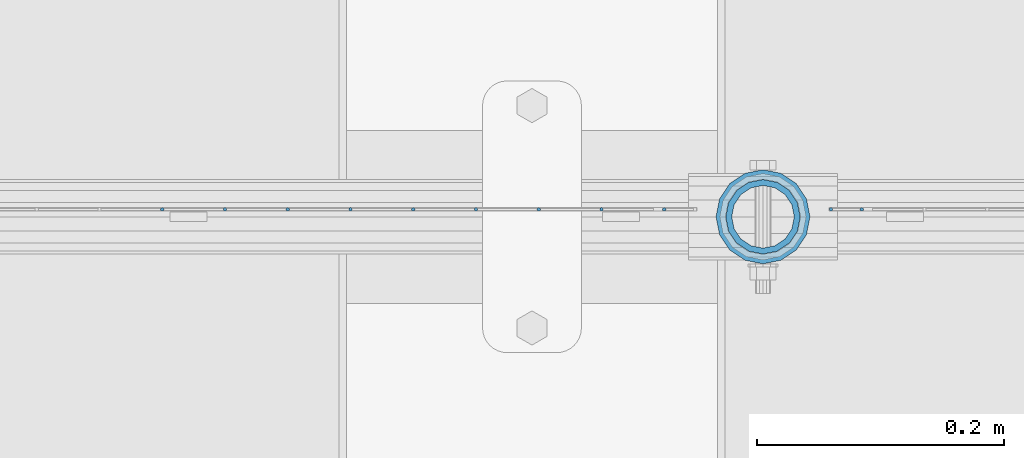
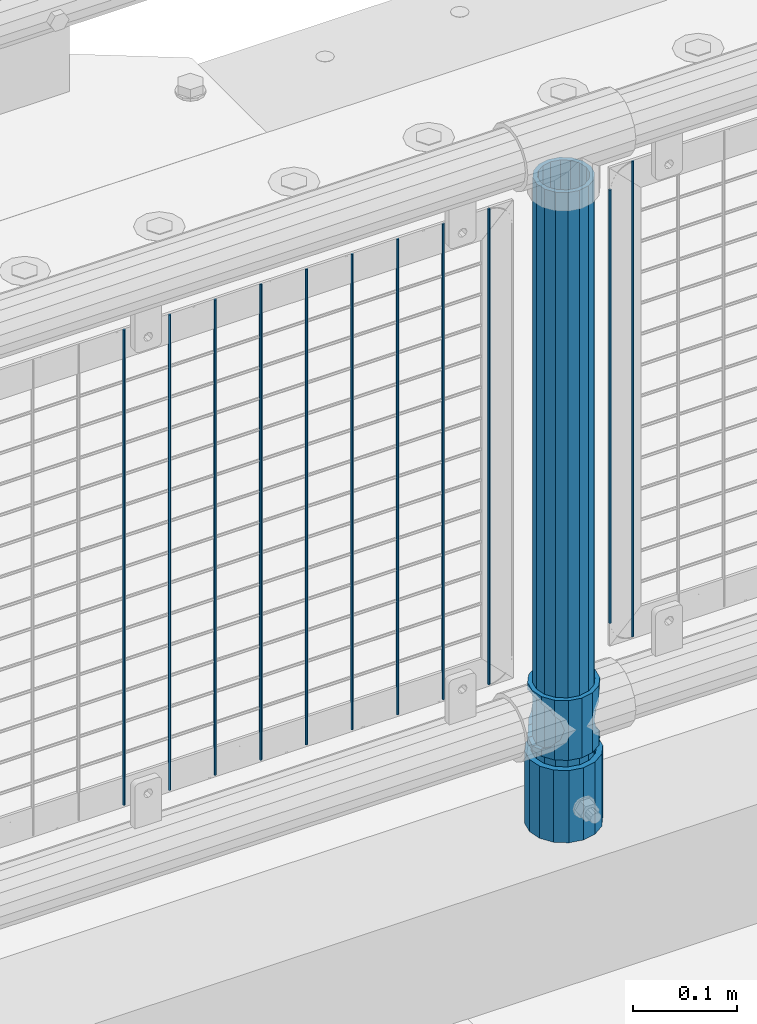
# One storey, part 73 of 270: 14 columns.
"""IFC2X3 building model written with IfcOpenShell, lengths in millimetres."""

from ifc_helpers import new_model, si_unit, frame, origin_with_axes, place, context, subcontext, project, spatial, faceted_brep, material, type_object, element, save


model = new_model("IFC2X3")

# Units and contexts
model_context = context("Model", 3, precision=1e-05, world=origin_with_axes())
body_context = subcontext(model_context, "Body", "Model", "MODEL_VIEW")
ifc_project = project(units=[si_unit("LENGTHUNIT", "METRE", prefix="MILLI"), si_unit("AREAUNIT", "SQUARE_METRE"), si_unit("VOLUMEUNIT", "CUBIC_METRE"), si_unit("MASSUNIT", "GRAM", prefix="KILO"), si_unit("TIMEUNIT", "SECOND"), si_unit("PLANEANGLEUNIT", "RADIAN"), si_unit("SOLIDANGLEUNIT", "STERADIAN"), si_unit("THERMODYNAMICTEMPERATUREUNIT", "DEGREE_CELSIUS"), si_unit("LUMINOUSINTENSITYUNIT", "LUMEN")], contexts=[model_context])

# Site, building, storey
site_placement = place(None, origin_with_axes())
site = spatial("IfcSite", under=ifc_project, at=site_placement, CompositionType="ELEMENT")
building_placement = place(site_placement, origin_with_axes())
building = spatial("IfcBuilding", under=site, at=building_placement, Name="Standard", CompositionType="ELEMENT")
storey_placement = place(building_placement, origin_with_axes())
storey = spatial("IfcBuildingStorey", under=building, at=storey_placement, Name="Undefined", CompositionType="ELEMENT", Elevation=0.0)

# Columns
ifc_material_1 = material()
column_type_1 = type_object("IfcColumnType", PredefinedType="NOTDEFINED")
column_1_placement = place(storey_placement, frame((3887.0, -16335.5, 168.02), z_axis=(-1.0, 0.0, 0.0), x_axis=(0.0, 0.0, 1.0)))
element("IfcColumn", 1, at=column_1_placement, inside=storey, type_object=column_type_1, material=ifc_material_1, context=body_context, shape_type="Brep", body=[
    faceted_brep([(0.0, -25.3500000000004, 0.0), (0.0, -23.4203461491616, 9.70102501045403), (760.0, -23.4203461491616, 9.70102501045403), (760.0, -25.3500000000004, 0.0), (0.0, -17.9251569030785, 17.9251569030785), (760.0, -17.9251569030785, 17.9251569030785), (0.0, -9.70102501045585, 23.4203461491597), (760.0, -9.70102501045585, 23.4203461491597), (0.0, 0.0, 25.3499999999985), (760.0, 0.0, 25.3499999999985), (0.0, 9.70102501045585, 23.4203461491597), (760.0, 9.70102501045585, 23.4203461491597), (0.0, 17.9251569030785, 17.9251569030785), (760.0, 17.9251569030785, 17.9251569030785), (0.0, 23.4203461491616, 9.70102501045403), (760.0, 23.4203461491616, 9.70102501045403), (0.0, 25.3500000000004, 0.0), (760.0, 25.3500000000004, 0.0), (0.0, 23.4203461491616, -9.70102501045403), (760.0, 23.4203461491616, -9.70102501045403), (0.0, 17.9251569030785, -17.9251569030785), (760.0, 17.9251569030785, -17.9251569030785), (0.0, 9.70102501045585, -23.4203461491597), (760.0, 9.70102501045585, -23.4203461491597), (0.0, 0.0, -25.3499999999985), (760.0, 0.0, -25.3499999999985), (0.0, -9.70102501045585, -23.4203461491597), (760.0, -9.70102501045585, -23.4203461491597), (0.0, -17.9251569030785, -17.9251569030785), (760.0, -17.9251569030785, -17.9251569030785), (0.0, -23.4203461491616, -9.70102501045403), (760.0, -23.4203461491616, -9.70102501045403), (0.0, -30.1499999999996, 0.0), (0.0, -27.8549679052157, -11.5379054858058), (760.0, -27.8549679052157, -11.5379054858058), (760.0, -30.1499999999996, 0.0), (0.0, -21.3192694527752, -21.3192694527752), (760.0, -21.3192694527752, -21.3192694527752), (0.0, -11.5379054858076, -27.8549679052157), (760.0, -11.5379054858076, -27.8549679052157), (0.0, 0.0, -30.1500000000015), (760.0, 0.0, -30.1500000000015), (0.0, 11.5379054858076, -27.8549679052157), (760.0, 11.5379054858076, -27.8549679052157), (0.0, 21.3192694527752, -21.3192694527752), (760.0, 21.3192694527752, -21.3192694527752), (0.0, 27.8549679052157, -11.5379054858058), (760.0, 27.8549679052157, -11.5379054858058), (0.0, 30.1499999999996, 0.0), (760.0, 30.1499999999996, 0.0), (0.0, 27.8549679052157, 11.5379054858058), (760.0, 27.8549679052157, 11.5379054858058), (0.0, 21.3192694527752, 21.3192694527752), (760.0, 21.3192694527752, 21.3192694527752), (0.0, 11.5379054858076, 27.8549679052157), (760.0, 11.5379054858076, 27.8549679052157), (0.0, 0.0, 30.1500000000015), (760.0, 0.0, 30.1500000000015), (0.0, -11.5379054858076, 27.8549679052157), (760.0, -11.5379054858076, 27.8549679052157), (0.0, -21.3192694527752, 21.3192694527752), (760.0, -21.3192694527752, 21.3192694527752), (0.0, -27.8549679052157, 11.5379054858058), (760.0, -27.8549679052157, 11.5379054858058)], [[[0, 1, 2, 3]], [[1, 4, 5, 2]], [[4, 6, 7, 5]], [[6, 8, 9, 7]], [[8, 10, 11, 9]], [[10, 12, 13, 11]], [[12, 14, 15, 13]], [[14, 16, 17, 15]], [[16, 18, 19, 17]], [[18, 20, 21, 19]], [[20, 22, 23, 21]], [[22, 24, 25, 23]], [[24, 26, 27, 25]], [[26, 28, 29, 27]], [[28, 30, 31, 29]], [[30, 0, 3, 31]], [[32, 33, 34, 35]], [[33, 36, 37, 34]], [[36, 38, 39, 37]], [[38, 40, 41, 39]], [[40, 42, 43, 41]], [[42, 44, 45, 43]], [[44, 46, 47, 45]], [[46, 48, 49, 47]], [[48, 50, 51, 49]], [[50, 52, 53, 51]], [[52, 54, 55, 53]], [[54, 56, 57, 55]], [[56, 58, 59, 57]], [[58, 60, 61, 59]], [[60, 62, 63, 61]], [[62, 32, 35, 63]], [[37, 39, 41, 43, 45, 47, 49, 51, 53, 55, 57, 59, 61, 63, 35, 34], [5, 7, 9, 11, 13, 15, 17, 19, 21, 23, 25, 27, 29, 31, 3, 2]], [[62, 60, 58, 56, 54, 52, 50, 48, 46, 44, 42, 40, 38, 36, 33, 32], [30, 28, 26, 24, 22, 20, 18, 16, 14, 12, 10, 8, 6, 4, 1, 0]]]),
])
column_type_2 = type_object("IfcColumnType", PredefinedType="NOTDEFINED")
column_2_placement = place(storey_placement, frame((3887.0, -16335.5, 168.02), z_axis=(0.0, 1.0, 0.0), x_axis=(0.0, 0.0, 1.0)))
element("IfcColumn", 2, at=column_2_placement, inside=storey, type_object=column_type_2, material=ifc_material_1, context=body_context, shape_type="Brep", body=[
    faceted_brep([(0.0, -31.75, 0.0), (0.0, -29.3331751572332, 12.1501989775916), (85.0, -29.3331751572332, 12.1501989775916), (85.0, -31.75, 0.0), (0.0, -22.4506403026717, 22.4506403026735), (85.0, -22.4506403026717, 22.4506403026735), (0.0, -12.1501989775934, 29.3331751572332), (85.0, -12.1501989775934, 29.3331751572332), (0.0, 0.0, 31.75), (85.0, 0.0, 31.75), (0.0, 12.1501989775934, 29.3331751572332), (85.0, 12.1501989775934, 29.3331751572332), (0.0, 22.4506403026717, 22.4506403026735), (85.0, 22.4506403026717, 22.4506403026735), (0.0, 29.3331751572332, 12.1501989775916), (85.0, 29.3331751572332, 12.1501989775916), (0.0, 31.75, 0.0), (85.0, 31.75, 0.0), (0.0, 29.3331751572332, -12.1501989775916), (85.0, 29.3331751572332, -12.1501989775916), (0.0, 22.4506403026717, -22.4506403026735), (85.0, 22.4506403026717, -22.4506403026735), (0.0, 12.1501989775934, -29.3331751572332), (85.0, 12.1501989775934, -29.3331751572332), (0.0, 0.0, -31.75), (85.0, 0.0, -31.75), (0.0, -12.1501989775934, -29.3331751572332), (85.0, -12.1501989775934, -29.3331751572332), (0.0, -22.4506403026717, -22.4506403026735), (85.0, -22.4506403026717, -22.4506403026735), (0.0, -29.3331751572332, -12.1501989775916), (85.0, -29.3331751572332, -12.1501989775916), (0.0, -38.0499999999993, 0.0), (0.0, -35.1536162120537, -14.561104601491), (85.0, -35.1536162120537, -14.561104601491), (85.0, -38.0499999999993, 0.0), (0.0, -26.9054130241493, -26.9054130241475), (85.0, -26.9054130241493, -26.9054130241475), (0.0, -14.5611046014928, -35.1536162120537), (85.0, -14.5611046014928, -35.1536162120537), (0.0, 0.0, -38.0499999999993), (85.0, 0.0, -38.0499999999993), (0.0, 14.5611046014928, -35.1536162120537), (85.0, 14.5611046014928, -35.1536162120537), (0.0, 26.9054130241493, -26.9054130241475), (85.0, 26.9054130241493, -26.9054130241475), (0.0, 35.1536162120537, -14.561104601491), (85.0, 35.1536162120537, -14.561104601491), (0.0, 38.0499999999993, 0.0), (85.0, 38.0499999999993, 0.0), (0.0, 35.1536162120537, 14.561104601491), (85.0, 35.1536162120537, 14.561104601491), (0.0, 26.9054130241493, 26.9054130241475), (85.0, 26.9054130241493, 26.9054130241475), (0.0, 14.5611046014928, 35.1536162120537), (85.0, 14.5611046014928, 35.1536162120537), (0.0, 0.0, 38.0499999999993), (85.0, 0.0, 38.0499999999993), (0.0, -14.5611046014928, 35.1536162120537), (85.0, -14.5611046014928, 35.1536162120537), (0.0, -26.9054130241493, 26.9054130241475), (85.0, -26.9054130241493, 26.9054130241475), (0.0, -35.1536162120537, 14.561104601491), (85.0, -35.1536162120537, 14.561104601491)], [[[0, 1, 2, 3]], [[1, 4, 5, 2]], [[4, 6, 7, 5]], [[6, 8, 9, 7]], [[8, 10, 11, 9]], [[10, 12, 13, 11]], [[12, 14, 15, 13]], [[14, 16, 17, 15]], [[16, 18, 19, 17]], [[18, 20, 21, 19]], [[20, 22, 23, 21]], [[22, 24, 25, 23]], [[24, 26, 27, 25]], [[26, 28, 29, 27]], [[28, 30, 31, 29]], [[30, 0, 3, 31]], [[32, 33, 34, 35]], [[33, 36, 37, 34]], [[36, 38, 39, 37]], [[38, 40, 41, 39]], [[40, 42, 43, 41]], [[42, 44, 45, 43]], [[44, 46, 47, 45]], [[46, 48, 49, 47]], [[48, 50, 51, 49]], [[50, 52, 53, 51]], [[52, 54, 55, 53]], [[54, 56, 57, 55]], [[56, 58, 59, 57]], [[58, 60, 61, 59]], [[60, 62, 63, 61]], [[62, 32, 35, 63]], [[37, 39, 41, 43, 45, 47, 49, 51, 53, 55, 57, 59, 61, 63, 35, 34], [5, 7, 9, 11, 13, 15, 17, 19, 21, 23, 25, 27, 29, 31, 3, 2]], [[62, 60, 58, 56, 54, 52, 50, 48, 46, 44, 42, 40, 38, 36, 33, 32], [30, 28, 26, 24, 22, 20, 18, 16, 14, 12, 10, 8, 6, 4, 1, 0]]]),
])
ifc_material_2 = material(Name="Misc_Undefined")
column_type_3 = type_object("IfcColumnType", PredefinedType="NOTDEFINED")
column_3_placement = place(storey_placement, frame((3887.0, -16335.5, 263.02), z_axis=(-1.0, 0.0, 0.0), x_axis=(0.0, 0.0, 1.0)))
element("IfcColumn", 3, at=column_3_placement, inside=storey, type_object=column_type_3, material=ifc_material_2, context=body_context, shape_type="Brep", body=[
    faceted_brep([(63.1897438117183, 11.6144421722802, -32.8397438117208), (63.1897438117183, 11.6144421722802, -28.0397438117179), (56.6106908090125, 21.4606908090118, -21.46069080901), (56.6106908090125, 21.4606908090118, -27.1226768591005), (61.9623795176767, 13.4513226476338, -32.4743655677703), (46.7644421722812, 28.0397438117179, -11.614442172282), (46.7644421722812, 28.0397438117179, -20.0882031229812), (51.5310424080071, 24.8548033587067, -24.8548033587067), (35.1500000000015, 30.35, 0.0), (35.1500000000008, 30.3500000000004, -16.6306603983612), (23.5355578277203, 28.0397438117179, -11.614442172282), (23.5355578277203, 28.0397438117179, -20.0882031229812), (18.7689575919954, 24.8548033587067, -24.8548033587067), (13.689309190989, 21.4606908090118, -21.46069080901), (13.689309190989, 21.4606908090118, -27.1226768591005), (8.33762048232484, 13.4513226476338, -32.4743655677703), (7.11025618828324, 11.6144421722802, -28.0397438117179), (7.11025618828324, 11.6144421722802, -32.8397438117208), (4.80000000000075, 0.0, -30.3499999999985), (4.80000000000075, 0.0, -35.1500000000015), (7.11025618828319, -11.6144421722802, -28.0397438117179), (7.11025618828319, -11.6144421722802, -32.8397438117172), (13.689309190989, -21.4606908090118, -21.46069080901), (13.689309190989, -21.4606908090118, -27.1226768591041), (8.33762048232484, -13.4513226476338, -32.4743655677703), (23.5355578277203, -28.0397438117179, -11.614442172282), (23.5355578277203, -28.0397438117179, -20.0882031229885), (18.7689575919954, -24.8548033587067, -24.8548033587067), (35.1500000000015, -30.35, 0.0), (35.1500000000008, -30.3500000000004, -16.6306603983721), (46.7644421722812, -28.0397438117179, -11.614442172282), (46.7644421722812, -28.0397438117179, -20.0882031229885), (51.5310424080071, -24.8548033587067, -24.8548033587067), (56.6106908090125, -21.4606908090118, -21.46069080901), (56.6106908090125, -21.4606908090118, -27.1226768591041), (61.9623795176767, -13.4513226476338, -32.4743655677703), (63.1897438117183, -11.6144421722802, -28.0397438117179), (63.1897438117183, -11.6144421722802, -32.8397438117172), (65.5000000000008, 0.0, -30.3499999999985), (65.5000000000008, 0.0, -35.1500000000015), (0.0, -28.0397438117179, -11.614442172282), (0.0, -30.3500000000004, 0.0), (0.0, -21.4606908090118, -21.46069080901), (0.0, -11.6144421722802, -28.0397438117179), (0.0, 0.0, -30.3499999999985), (0.0, 11.6144421722802, -28.0397438117179), (0.0, 21.4606908090118, -21.46069080901), (0.0, 28.0397438117179, -11.614442172282), (0.0, 30.3500000000004, 0.0), (0.0, 28.0397438117179, 11.614442172282), (23.5355578277192, 28.0397438117179, 11.614442172282), (0.0, 21.4606908090118, 21.46069080901), (13.6893091909879, 21.4606908090118, 21.46069080901), (0.0, 11.6144421722802, 28.0397438117179), (7.11025618828211, 11.6144421722802, 28.0397438117179), (0.0, 0.0, 30.3499999999985), (4.79999999999961, 0.0, 30.3499999999985), (0.0, -11.6144421722802, 28.0397438117179), (7.11025618828205, -11.6144421722802, 28.0397438117179), (0.0, -21.4606908090118, 21.46069080901), (13.6893091909879, -21.4606908090118, 21.46069080901), (0.0, -28.0397438117179, 11.614442172282), (23.5355578277191, -28.0397438117179, 11.614442172282), (0.0, -32.4743655677721, 13.4513226476338), (0.0, -35.1499999999996, 0.0), (70.2999999999993, -35.1499999999996, 0.0), (70.2999999999993, -32.4743655677721, 13.4513226476338), (0.0, 13.4513226476338, -32.4743655677703), (0.0, 24.8548033587067, -24.8548033587067), (0.0, 0.0, -35.1499999999996), (0.0, -13.4513226476338, -32.4743655677703), (0.0, -24.8548033587067, -24.8548033587067), (0.0, -24.8548033587067, 24.8548033587067), (0.0, -13.4513226476338, 32.4743655677703), (0.0, 0.0, 35.1499999999996), (0.0, 13.4513226476338, 32.4743655677703), (0.0, 24.8548033587067, 24.8548033587067), (0.0, 32.4743655677721, 13.4513226476338), (0.0, 35.1499999999996, 0.0), (0.0, 32.4743655677721, -13.4513226476338), (0.0, -32.4743655677721, -13.4513226476338), (70.2999999999993, 32.4743655677721, 13.4513226476338), (70.2999999999993, 35.1499999999996, 0.0), (70.2999999999993, 32.4743655677721, -13.4513226476338), (70.2999999999993, 24.8548033587067, -24.8548033587067), (70.2999999999993, 13.4513226476338, -32.4743655677703), (70.2999999999993, 0.0, -35.1500000000015), (70.2999999999993, -13.4513226476338, -32.4743655677703), (70.2999999999993, -24.8548033587067, -24.8548033587067), (70.2999999999993, -32.4743655677721, -13.4513226476338), (70.2999999999993, 28.0397438117179, 11.614442172282), (70.2999999999993, 21.4606908090118, 21.46069080901), (56.6106908090114, 21.4606908090118, 21.46069080901), (46.7644421722801, 28.0397438117179, 11.614442172282), (70.2999999999993, 11.6144421722802, 28.0397438117179), (63.1897438117172, 11.6144421722802, 28.0397438117179), (70.2999999999993, 0.0, 30.3499999999985), (65.4999999999997, 0.0, 30.3499999999985), (70.2999999999993, -11.6144421722802, 28.0397438117179), (63.1897438117172, -11.6144421722802, 28.0397438117179), (70.2999999999993, -21.4606908090118, 21.46069080901), (56.6106908090114, -21.4606908090118, 21.46069080901), (70.2999999999993, -28.0397438117179, 11.614442172282), (46.7644421722801, -28.0397438117179, 11.614442172282), (70.2999999999993, -11.6144421722802, -28.0397438117179), (70.2999999999993, 0.0, -30.3499999999985), (70.2999999999993, -21.4606908090118, -21.46069080901), (70.2999999999993, -28.0397438117179, -11.614442172282), (70.2999999999993, -30.3500000000004, 0.0), (70.2999999999993, 24.8548033587067, 24.8548033587067), (70.2999999999993, 13.4513226476338, 32.4743655677703), (70.2999999999993, 0.0, 35.1500000000015), (70.2999999999993, -13.4513226476338, 32.4743655677703), (70.2999999999993, -24.8548033587067, 24.8548033587067), (70.2999999999993, 30.3500000000004, 0.0), (70.2999999999993, 28.0397438117179, -11.614442172282), (70.2999999999993, 21.4606908090118, -21.46069080901), (70.2999999999993, 11.6144421722802, -28.0397438117179), (61.9623795176767, 13.4513226476338, 32.4743655677703), (51.5310424080039, 24.8548033587067, 24.8548033587067), (56.6106908090114, 21.4606908090118, 27.1226768591041), (65.4999999999997, 0.0, 35.1500000000015), (63.1897438117172, 11.6144421722802, 32.8397438117172), (63.1897438117172, -11.6144421722802, 32.8397438117172), (61.9623795176767, -13.4513226476338, 32.4743655677703), (56.6106908090114, -21.4606908090118, 27.1226768591077), (51.5310424080071, -24.8548033587067, 24.8548033587067), (18.7689575919954, -24.8548033587067, 24.8548033587067), (46.7644421722801, -28.0397438117179, 20.0882031229849), (35.1499999999996, -30.3500000000004, 16.6306603983649), (23.5355578277191, -28.0397438117179, 20.0882031229849), (8.33762048232262, -13.4513226476338, 32.4743655677703), (13.6893091909879, -21.4606908090118, 27.1226768591077), (4.79999999999961, 0.0, 35.1500000000015), (7.11025618828205, -11.6144421722802, 32.8397438117172), (7.11025618828211, 11.6144421722802, 32.8397438117172), (8.33762048232262, 13.4513226476338, 32.4743655677703), (13.6893091909879, 21.4606908090118, 27.1226768591041), (18.7689575919954, 24.8548033587067, 24.8548033587067), (23.5355578277192, 28.0397438117179, 20.0882031229885), (35.1499999999996, 30.3500000000004, 16.6306603983685), (46.7644421722801, 28.0397438117179, 20.0882031229885)], [[[0, 1, 2, 3, 4]], [[3, 2, 5, 6, 7]], [[6, 5, 8, 9]], [[9, 8, 10, 11]], [[12, 11, 10, 13, 14]], [[15, 14, 13, 16, 17]], [[17, 16, 18, 19]], [[19, 18, 20, 21]], [[21, 20, 22, 23, 24]], [[23, 22, 25, 26, 27]], [[26, 25, 28, 29]], [[29, 28, 30, 31]], [[32, 31, 30, 33, 34]], [[35, 34, 33, 36, 37]], [[37, 36, 38, 39]], [[39, 38, 1, 0]], [[40, 41, 28, 25]], [[42, 40, 25, 22]], [[43, 42, 22, 20]], [[44, 43, 20, 18]], [[45, 44, 18, 16]], [[46, 45, 16, 13]], [[47, 46, 13, 10]], [[48, 47, 10, 8]], [[49, 48, 8, 50]], [[51, 49, 50, 52]], [[53, 51, 52, 54]], [[55, 53, 54, 56]], [[57, 55, 56, 58]], [[59, 57, 58, 60]], [[61, 59, 60, 62]], [[41, 61, 62, 28]], [[63, 64, 65, 66]], [[67, 68, 12, 14, 15]], [[69, 67, 15, 17, 19]], [[24, 70, 69, 19, 21]], [[27, 71, 70, 24, 23]], [[63, 72, 73, 74, 75, 76, 77, 78, 79, 68, 67, 69, 70, 71, 80, 64], [40, 42, 43, 44, 45, 46, 47, 48, 49, 51, 53, 55, 57, 59, 61, 41]], [[78, 77, 81, 82]], [[79, 78, 82, 83]], [[68, 79, 83, 84, 7, 6, 9, 11, 12]], [[7, 84, 85, 4, 3]], [[4, 85, 86, 39, 0]], [[87, 88, 32, 34, 35]], [[86, 87, 35, 37, 39]], [[29, 31, 32, 88, 89, 80, 71, 27, 26]], [[64, 80, 89, 65]], [[90, 91, 92, 93]], [[91, 94, 95, 92]], [[94, 96, 97, 95]], [[96, 98, 99, 97]], [[98, 100, 101, 99]], [[100, 102, 103, 101]], [[104, 105, 38, 36]], [[106, 104, 36, 33]], [[107, 106, 33, 30]], [[108, 107, 30, 28]], [[102, 108, 28, 103]], [[88, 87, 86, 85, 84, 83, 82, 81, 109, 110, 111, 112, 113, 66, 65, 89], [100, 98, 96, 94, 91, 90, 114, 115, 116, 117, 105, 104, 106, 107, 108, 102]], [[118, 110, 109, 119, 120]], [[121, 111, 110, 118, 122]], [[112, 111, 121, 123, 124]], [[113, 112, 124, 125, 126]], [[127, 72, 63, 66, 113, 126, 128, 129, 130]], [[131, 73, 72, 127, 132]], [[133, 74, 73, 131, 134]], [[75, 74, 133, 135, 136]], [[76, 75, 136, 137, 138]], [[119, 109, 81, 77, 76, 138, 139, 140, 141]], [[92, 120, 119, 141, 93]], [[95, 122, 118, 120, 92]], [[97, 121, 122, 95]], [[99, 123, 121, 97]], [[101, 125, 124, 123, 99]], [[103, 128, 126, 125, 101]], [[28, 129, 128, 103]], [[62, 130, 129, 28]], [[60, 132, 127, 130, 62]], [[58, 134, 131, 132, 60]], [[56, 133, 134, 58]], [[54, 135, 133, 56]], [[52, 137, 136, 135, 54]], [[50, 139, 138, 137, 52]], [[8, 140, 139, 50]], [[93, 141, 140, 8]], [[114, 90, 93, 8]], [[115, 114, 8, 5]], [[116, 115, 5, 2]], [[117, 116, 2, 1]], [[105, 117, 1, 38]]]),
])
column_type_4 = type_object("IfcColumnType", Name="D3", PredefinedType="NOTDEFINED")
column_4_placement = place(storey_placement, frame((3942.0, -16329.5, 378.02), z_axis=(-1.0, 0.0, 0.0), x_axis=(0.0, 0.0, 1.0)))
element("IfcColumn", 4, at=column_4_placement, inside=storey, type_object=column_type_4, material=ifc_material_2, ObjectType="D3", context=body_context, shape_type="Brep", body=[
    faceted_brep([(0.0, -1.5, 0.0), (0.0, -0.75, -1.29903810567669), (510.0, -0.75, -1.29903810567703), (510.0, -1.5, 0.0), (0.0, 0.75, -1.29903810567669), (510.0, 0.75, -1.29903810567703), (0.0, 1.5, 0.0), (510.0, 1.5, 0.0), (0.0, 0.75, 1.29903810567669), (510.0, 0.75, 1.29903810567703), (0.0, -0.75, 1.29903810567669), (510.0, -0.75, 1.29903810567703)], [[[0, 1, 2, 3]], [[1, 4, 5, 2]], [[4, 6, 7, 5]], [[6, 8, 9, 7]], [[8, 10, 11, 9]], [[10, 0, 3, 11]], [[5, 7, 9, 11, 3, 2]], [[10, 8, 6, 4, 1, 0]]]),
])
for number, where, z_axis, x_axis in (
    (5, (3967.0, -16329.5, 353.02), (-1.0, 0.0, 0.0), (0.0, 0.0, 1.0)),
    (6, (3756.204, -16329.5, 353.02), (-1.0, 0.0, 0.0), (0.0, 0.0, 1.0)),
    (7, (3705.411, -16329.5, 353.02), (-1.0, 0.0, 0.0), (0.0, 0.0, 1.0)),
    (8, (3654.618, -16329.5, 353.02), (-1.0, 0.0, 0.0), (0.0, 0.0, 1.0)),
    (9, (3603.825, -16329.5, 353.02), (-1.0, 0.0, 0.0), (0.0, 0.0, 1.0)),
    (10, (3553.032, -16329.5, 353.02), (-1.0, 0.0, 0.0), (0.0, 0.0, 1.0)),
    (11, (3502.239, -16329.5, 353.02), (-1.0, 0.0, 0.0), (0.0, 0.0, 1.0)),
    (12, (3451.446, -16329.5, 353.02), (-1.0, 0.0, 0.0), (0.0, 0.0, 1.0)),
    (13, (3806.997, -16329.5, 353.02), (-1.0, 0.0, 0.0), (0.0, 0.0, 1.0)),
    (14, (3400.653, -16329.5, 353.02), (-1.0, 0.0, 0.0), (0.0, 0.0, 1.0)),
):
    element("IfcColumn", number, at=place(storey_placement, frame(where, z_axis=z_axis, x_axis=x_axis)), inside=storey, type_object=column_type_4, material=ifc_material_2, ObjectType="D3", context=body_context, shape_type="Brep", body=[
        faceted_brep([(0.0, -1.5, 0.0), (0.0, -0.75, -1.29903810567669), (560.0, -0.75, -1.29903810567703), (560.0, -1.5, 0.0), (0.0, 0.75, -1.29903810567669), (560.0, 0.75, -1.29903810567703), (0.0, 1.5, 0.0), (560.0, 1.5, 0.0), (0.0, 0.75, 1.29903810567669), (560.0, 0.75, 1.29903810567703), (0.0, -0.75, 1.29903810567669), (560.0, -0.75, 1.29903810567703)], [[[0, 1, 2, 3]], [[1, 4, 5, 2]], [[4, 6, 7, 5]], [[6, 8, 9, 7]], [[8, 10, 11, 9]], [[10, 0, 3, 11]], [[5, 7, 9, 11, 3, 2]], [[10, 8, 6, 4, 1, 0]]]),
    ])

save(model, "model.ifc")
